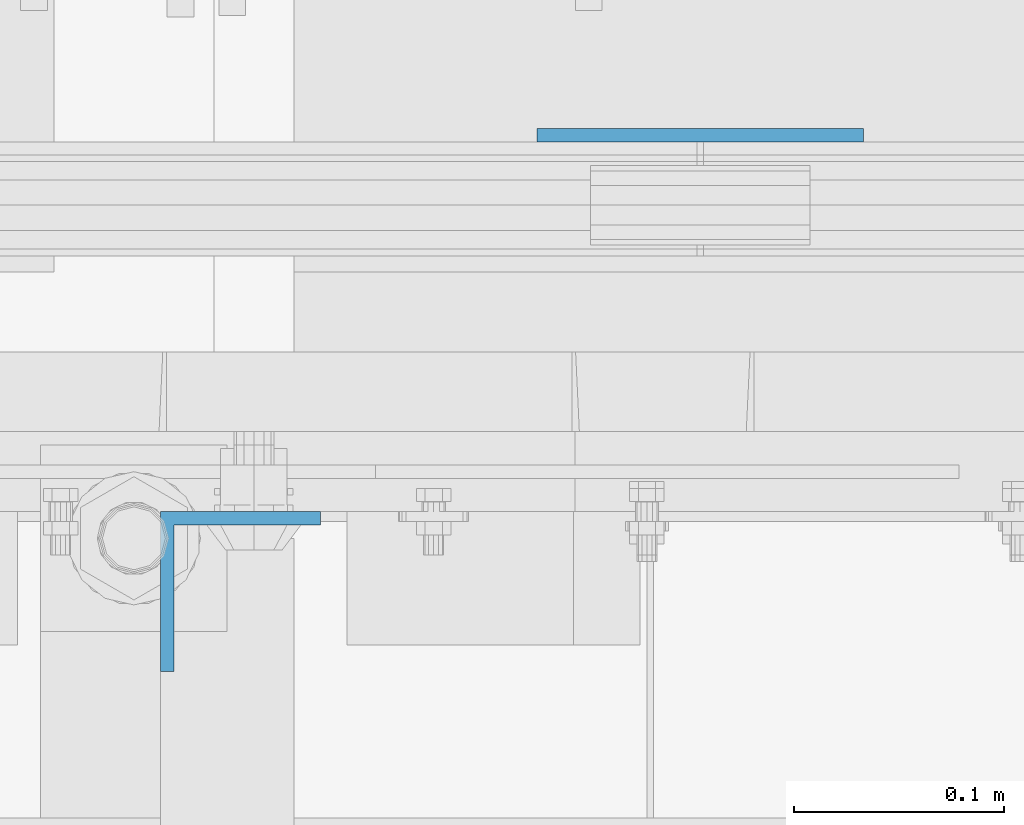
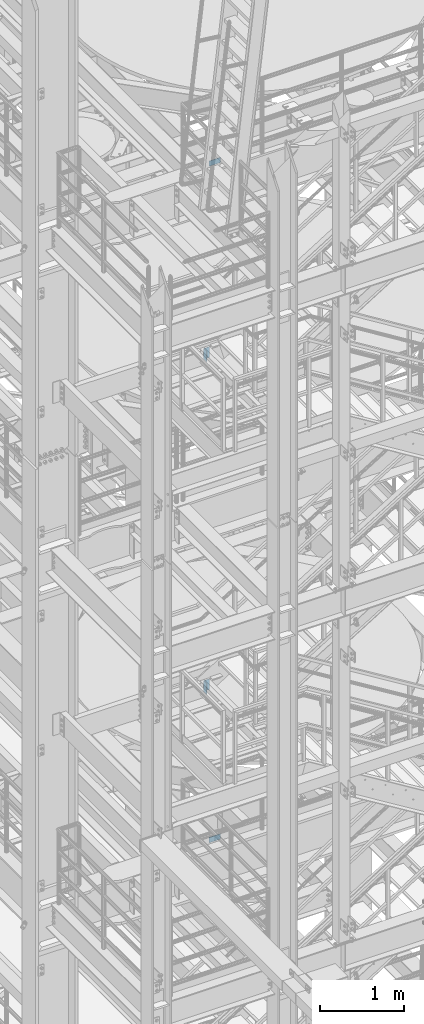
# One storey, part 824 of 1876: 4 columns, 4 elements without a shape of their own.
"""IFC2X3 building model written with IfcOpenShell, lengths in millimetres."""

from ifc_helpers import new_model, si_unit, frame, origin_with_axes, place, context, subcontext, project, spatial, faceted_brep, material, type_object, element, aggregate, save


model = new_model("IFC2X3")

# Units and contexts
model_context = context("Model", 3, precision=1e-05, world=origin_with_axes())
body_context = subcontext(model_context, "Body", "Model", "MODEL_VIEW")
ifc_project = project(units=[si_unit("LENGTHUNIT", "METRE", prefix="MILLI"), si_unit("AREAUNIT", "SQUARE_METRE"), si_unit("VOLUMEUNIT", "CUBIC_METRE"), si_unit("MASSUNIT", "GRAM", prefix="KILO"), si_unit("TIMEUNIT", "SECOND"), si_unit("PLANEANGLEUNIT", "RADIAN"), si_unit("SOLIDANGLEUNIT", "STERADIAN"), si_unit("THERMODYNAMICTEMPERATUREUNIT", "DEGREE_CELSIUS"), si_unit("LUMINOUSINTENSITYUNIT", "LUMEN")], contexts=[model_context])

# Site, building, storey
site_placement = place(None, origin_with_axes())
site = spatial("IfcSite", under=ifc_project, at=site_placement, CompositionType="ELEMENT")
building_placement = place(site_placement, origin_with_axes())
building = spatial("IfcBuilding", under=site, at=building_placement, Name="Undefined", CompositionType="ELEMENT")
storey_placement = place(building_placement, origin_with_axes())
storey = spatial("IfcBuildingStorey", under=building, at=storey_placement, Name="Undefined", CompositionType="ELEMENT", Elevation=0.0)

# Assembly, column
assembly_1_placement = place(storey_placement, origin_with_axes())
assembly_1 = element("IfcElementAssembly", 1, at=assembly_1_placement, inside=storey, Name="RAIL", AssemblyPlace="NOTDEFINED", PredefinedType="RIGID_FRAME")
ifc_material = material(Name="STEEL/A36")
column_type_1 = type_object("IfcColumnType", PredefinedType="NOTDEFINED")
column_1_placement = place(assembly_1_placement, frame((2238.37499998823, -4621.21250191054, 8181.975), z_axis=(-1.0, 0.0, 0.0), x_axis=(0.0, 0.0, 1.0)))
column_1 = element("IfcColumn", 2, at=column_1_placement, type_object=column_type_1, material=ifc_material, Name="PLATE", context=body_context, shape_type="Brep", body=[
    faceted_brep([(0.0, 3.17500000000018, -77.7874999999999), (0.0, 3.17500000000018, 77.7874999999999), (76.1999999999971, 3.17500000000018, 77.7874999999999), (76.1999999999971, 3.17500000000018, -77.7874999999999), (0.0, -3.17500000000018, 77.7874999999999), (76.1999999999971, -3.17500000000018, 77.7874999999999), (0.0, -3.17500000000018, -77.7874999999999), (76.1999999999971, -3.17500000000018, -77.7874999999999)], [[[0, 1, 2, 3]], [[1, 4, 5, 2]], [[4, 6, 7, 5]], [[6, 0, 3, 7]], [[5, 7, 3, 2]], [[6, 4, 1, 0]]]),
])
aggregate(assembly_1, [column_1])

assembly_2_placement = place(storey_placement, origin_with_axes())
assembly_2 = element("IfcElementAssembly", 3, at=assembly_2_placement, inside=storey, Name="RAIL", AssemblyPlace="NOTDEFINED", PredefinedType="RIGID_FRAME")
column_2_placement = place(assembly_2_placement, frame((2238.37499998823, -4621.21250191054, 18011.775), z_axis=(-1.0, 0.0, 0.0), x_axis=(0.0, 0.0, 1.0)))
column_2 = element("IfcColumn", 4, at=column_2_placement, type_object=column_type_1, material=ifc_material, Name="PLATE", context=body_context, shape_type="Brep", body=[
    faceted_brep([(0.0, 3.17500000000018, -77.7874999999999), (0.0, 3.17500000000018, 77.7874999999999), (76.1999999999971, 3.17500000000018, 77.7874999999999), (76.1999999999971, 3.17500000000018, -77.7874999999999), (0.0, -3.17500000000018, 77.7874999999999), (76.1999999999971, -3.17500000000018, 77.7874999999999), (0.0, -3.17500000000018, -77.7874999999999), (76.1999999999971, -3.17500000000018, -77.7874999999999)], [[[0, 1, 2, 3]], [[1, 4, 5, 2]], [[4, 6, 7, 5]], [[6, 0, 3, 7]], [[5, 7, 3, 2]], [[6, 4, 1, 0]]]),
])
aggregate(assembly_2, [column_2])

assembly_3_placement = place(storey_placement, origin_with_axes())
assembly_3 = element("IfcElementAssembly", 5, at=assembly_3_placement, inside=storey, Name="STRINGER", AssemblyPlace="NOTDEFINED", PredefinedType="RIGID_FRAME")
column_type_2 = type_object("IfcColumnType", Name="L3X3X1/4", PredefinedType="NOTDEFINED")
column_3_placement = place(assembly_3_placement, frame((2019.3, -4838.70000114532, 15385.2867791615), z_axis=(0.0, -1.0, 0.0), x_axis=(0.0, 0.0, 1.0)))
column_3 = element("IfcColumn", 6, at=column_3_placement, type_object=column_type_2, material=ifc_material, Name="ANGLE", ObjectType="L3X3X1/4", context=body_context, shape_type="Brep", body=[
    faceted_brep([(0.0, 38.1000000000004, -38.1), (0.0, 38.1000000000004, 38.1), (152.4, 38.1000000000004, 38.1), (152.4, 38.1000000000004, -38.1), (0.0, 31.75, 38.1000000000004), (152.4, 31.75, 38.0999999999999), (0.0, 31.75, -31.75), (152.4, 31.75, -31.75), (0.0, -38.1000000000004, -31.75), (152.4, -38.1000000000004, -31.75), (0.0, -38.1000000000004, -38.1), (152.4, -38.1000000000004, -38.1)], [[[0, 1, 2, 3]], [[1, 4, 5, 2]], [[4, 6, 7, 5]], [[6, 8, 9, 7]], [[8, 10, 11, 9]], [[10, 0, 3, 11]], [[5, 7, 9, 11, 3, 2]], [[10, 8, 6, 4, 1, 0]]]),
])
aggregate(assembly_3, [column_3])

assembly_4_placement = place(storey_placement, origin_with_axes())
assembly_4 = element("IfcElementAssembly", 7, at=assembly_4_placement, inside=storey, Name="STRINGER", AssemblyPlace="NOTDEFINED", PredefinedType="RIGID_FRAME")
column_4_placement = place(assembly_4_placement, frame((2019.30000034613, -4838.70000114845, 10556.875), z_axis=(0.0, -1.0, 0.0), x_axis=(0.0, 0.0, 1.0)))
column_4 = element("IfcColumn", 8, at=column_4_placement, type_object=column_type_2, material=ifc_material, Name="ANGLE", ObjectType="L3X3X1/4", context=body_context, shape_type="Brep", body=[
    faceted_brep([(0.0, 38.1000000000004, -38.1), (0.0, 38.1000000000004, 38.1), (152.4, 38.1000000000004, 38.1), (152.4, 38.1000000000004, -38.1), (0.0, 31.75, 38.1000000000004), (152.4, 31.75, 38.0999999999999), (0.0, 31.75, -31.75), (152.4, 31.75, -31.75), (0.0, -38.1000000000004, -31.75), (152.4, -38.1000000000004, -31.75), (0.0, -38.1000000000004, -38.1), (152.4, -38.1000000000004, -38.1)], [[[0, 1, 2, 3]], [[1, 4, 5, 2]], [[4, 6, 7, 5]], [[6, 8, 9, 7]], [[8, 10, 11, 9]], [[10, 0, 3, 11]], [[5, 7, 9, 11, 3, 2]], [[10, 8, 6, 4, 1, 0]]]),
])
aggregate(assembly_4, [column_4])

save(model, "model.ifc")
